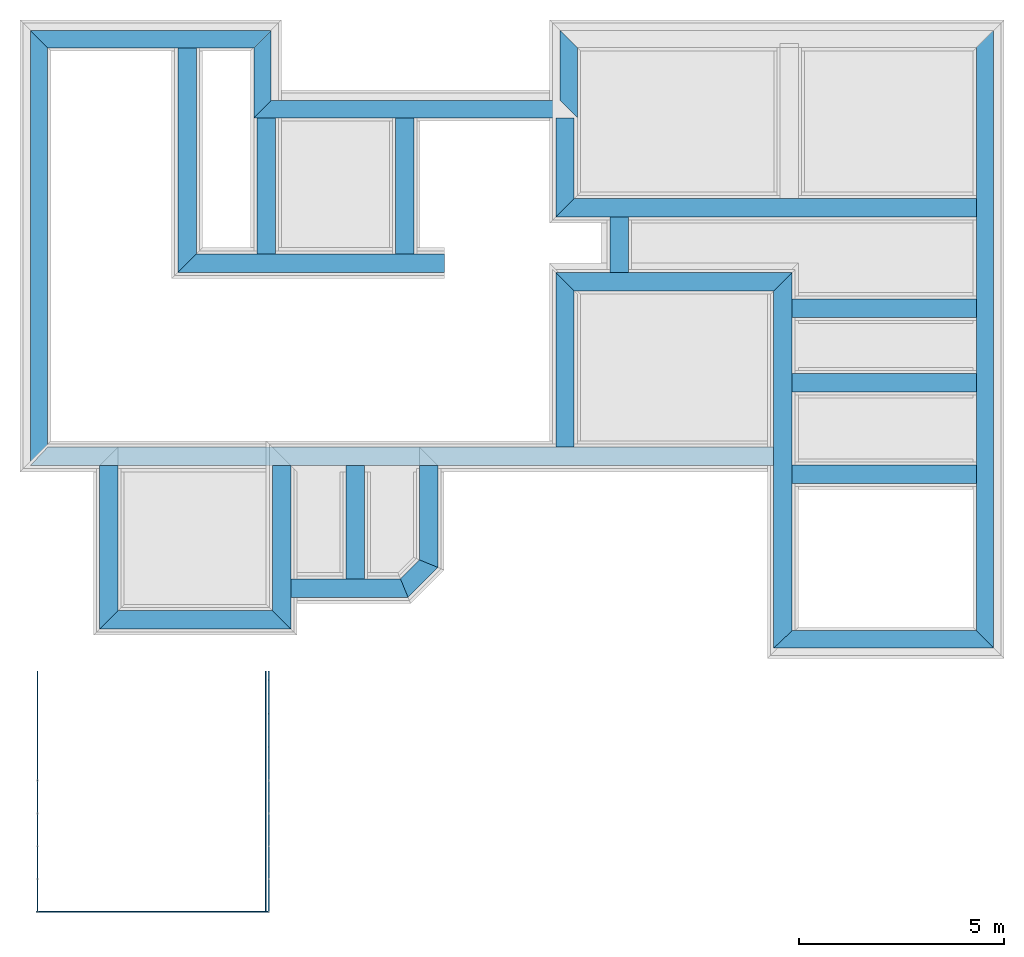
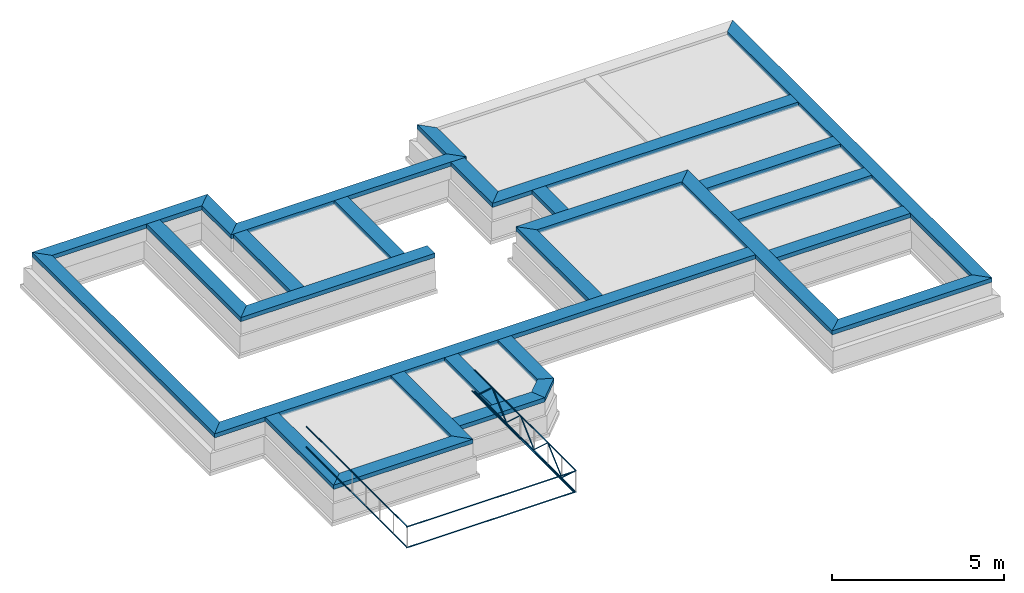
# One storey, part 1 of 7: 42 beams.
"""IFC4X3_ADD2 building model written with IfcOpenShell, lengths in metres."""

from ifc_helpers import new_model, entity, si_unit, converted_unit, frame, origin_with_axes, origin_2d_with_axis, place, context, subcontext, project, spatial, line, indexed_curve, hollow_rectangle, outline, extrude, material, layer, layer_set, layer_usage, material_profile, profile_set, profile_usage, type_object, element, save


model = new_model("IFC4X3_ADD2")

# Units and contexts
model_context = context("Model", 3, precision=1e-05, world=origin_with_axes())
plan_context = context("Plan", 2, precision=1e-05, world=origin_2d_with_axis())
body_context = subcontext(model_context, "Body", "Model", "MODEL_VIEW")
ifc_project = project(units=[si_unit("VOLUMEUNIT", "CUBIC_METRE"), si_unit("LENGTHUNIT", "METRE"), converted_unit("PLANEANGLEUNIT", "degree", entity("IfcReal", 0.0174532925199433), si_unit("PLANEANGLEUNIT", "RADIAN"), dimensions=[0, 0, 0, 0, 0, 0, 0]), si_unit("AREAUNIT", "SQUARE_METRE")], contexts=[model_context, plan_context])

# Site, building, storey
site_placement = place(None, origin_with_axes())
site = spatial("IfcSite", under=ifc_project, at=site_placement)
building_placement = place(site_placement, origin_with_axes())
building = spatial("IfcBuilding", under=site, at=building_placement, Name="Building")
storey_placement = place(building_placement, frame((0.0, 0.0, -0.870000004768372), z_axis=(0.0, 0.0, 1.0), x_axis=(1.0, 0.0, 0.0)))
storey = spatial("IfcBuildingStorey", under=building, at=storey_placement, Name="Footing")

# Beams
ifc_material_1 = material(Name="brick2", Category="Materials")
ifc_layer_1 = layer(ifc_material_1, 0.00999999977648258)
ifc_material_2 = material(Name="Concrete")
ifc_layer_2 = layer(ifc_material_2, 0.405000001192093)
ifc_layer_3 = layer(ifc_material_1, 0.00999999977648258)
ifc_layer_set_1 = layer_set([ifc_layer_1, ifc_layer_2, ifc_layer_3], Name="concrete")
ifc_layer_usage_1 = layer_usage(ifc_layer_set_1, "AXIS2", "POSITIVE", 0.0)
beam_type_1 = type_object("IfcBeamType", Name="425mm wide beam", PredefinedType="BEAM", material=ifc_layer_set_1)
beam_1_placement = place(storey_placement, frame((18.1166839599609, 25.9979019165039, 1.16999995708466), z_axis=(0.0, 0.0, 1.0), x_axis=(3.13916473260163e-07, -0.999999999999951, 0.0)))
element("IfcBeam", 1, at=beam_1_placement, inside=storey, type_object=beam_type_1, material=ifc_layer_usage_1, Name="Beam", context=body_context, shape_type="SweptSolid", body=[
    extrude(outline(indexed_curve([(-0.425000000745059, 0.0), (-1.85773430742357e-08, 0.425000000745058), (1.70799196416283, 0.425000000745058), (1.28299198199511, 0.0)], segments=[line(1, 2, 3, 4, 1)])), origin_with_axes(), (0.0, 0.0, 1.0), 0.150000005960464),
])
ifc_layer_usage_2 = layer_usage(ifc_layer_set_1, "AXIS2", "POSITIVE", 0.0)
beam_2_placement = place(storey_placement, frame((10.6593037587962, 24.2899072712673, 1.16999995708466), z_axis=(0.0, 0.0, 1.0), x_axis=(0.999999999999936, 3.57627868652321e-07, 0.0)))
element("IfcBeam", 2, at=beam_2_placement, inside=storey, type_object=beam_type_1, material=ifc_layer_usage_2, Name="Beam", context=body_context, shape_type="SweptSolid", body=[
    extrude(outline(indexed_curve([(0.0, 0.0), (0.425000048504974, 0.425000000745058), (7.45738073603171, 0.425000000745058), (7.88238071161483, 0.0)], segments=[line(1, 2, 3, 4, 1)])), origin_with_axes(), (0.0, 0.0, 1.0), 0.150000005960464),
])
ifc_layer_usage_3 = layer_usage(ifc_layer_set_1, "AXIS2", "POSITIVE", 0.0)
beam_3_placement = place(storey_placement, frame((28.2616729736329, 25.9979055491053, 1.16999995708466), z_axis=(0.0, 0.0, 1.0), x_axis=(3.13916473260163e-07, -0.999999999999951, 0.0)))
element("IfcBeam", 3, at=beam_3_placement, inside=storey, type_object=beam_type_1, material=ifc_layer_usage_3, Name="Beam", context=body_context, shape_type="SweptSolid", body=[
    extrude(outline(indexed_curve([(0.0, 0.0), (-0.425000019322402, 0.425000000745058), (14.6285606951178, 0.425000000745058), (14.2035607129501, 0.0)], segments=[line(1, 2, 3, 4, 1)])), origin_with_axes(), (0.0, 0.0, 1.0), 0.150000005960464),
])
ifc_layer_usage_4 = layer_usage(ifc_layer_set_1, "AXIS2", "POSITIVE", 0.0)
beam_4_placement = place(storey_placement, frame((23.3250172254903, 11.3693430699236, 1.16999995708466), z_axis=(0.0, 0.0, 1.0), x_axis=(0.999999999999936, 3.57627868652321e-07, 0.0)))
element("IfcBeam", 4, at=beam_4_placement, inside=storey, type_object=beam_type_1, material=ifc_layer_usage_4, Name="Beam", context=body_context, shape_type="SweptSolid", body=[
    extrude(outline(indexed_curve([(0.0, 0.0), (0.450000020620197, 0.425000000745058), (4.93666035886637, 0.425000000745058), (5.36166034103409, 0.0)], segments=[line(1, 2, 3, 4, 1)])), origin_with_axes(), (0.0, 0.0, 1.0), 0.150000005960464),
])
ifc_layer_usage_5 = layer_usage(ifc_layer_set_1, "AXIS2", "POSITIVE", 0.0)
beam_5_placement = place(storey_placement, frame((5.21403593350073, 25.9879012442737, 1.16999995708466), z_axis=(0.0, 0.0, 1.0), x_axis=(3.13916473260163e-07, -0.999999999999951, 0.0)))
element("IfcBeam", 5, at=beam_5_placement, inside=storey, type_object=beam_type_1, material=ifc_layer_usage_5, Name="Beam", context=body_context, shape_type="SweptSolid", body=[
    extrude(outline(indexed_curve([(-0.425000000745059, 0.0), (-1.85773430742357e-08, 0.425000000745058), (9.7218833779098, 0.425000000745058), (10.1718834035535, 0.0)], segments=[line(1, 2, 3, 4, 1)])), origin_with_axes(), (0.0, 0.0, 1.0), 0.150000005960464),
])
ifc_layer_usage_6 = layer_usage(ifc_layer_set_1, "AXIS2", "POSITIVE", 0.0)
beam_6_placement = place(storey_placement, frame((5.21403593350073, 25.9879012442737, 1.16999995708466), z_axis=(0.0, 0.0, 1.0), x_axis=(0.999999999999936, 3.57627868652321e-07, 0.0)))
element("IfcBeam", 6, at=beam_6_placement, inside=storey, type_object=beam_type_1, material=ifc_layer_usage_6, Name="Beam", context=body_context, shape_type="SweptSolid", body=[
    extrude(outline(indexed_curve([(0.425000000745059, 0.0), (1.96829825992962e-08, 0.425000000745058), (5.87026742918612, 0.425000000745058), (5.44526740885958, 0.0)], segments=[line(1, 2, 3, 4, 1)])), origin_with_axes(), (0.0, 0.0, 1.0), 0.150000005960464),
])
ifc_layer_usage_7 = layer_usage(ifc_layer_set_1, "AXIS2", "POSITIVE", 0.0)
beam_7_placement = place(storey_placement, frame((10.65930334236, 25.9879031916531, 1.16999995708466), z_axis=(0.0, 0.0, 1.0), x_axis=(3.13916473260163e-07, -0.999999999999951, 0.0)))
element("IfcBeam", 7, at=beam_7_placement, inside=storey, type_object=beam_type_1, material=ifc_layer_usage_7, Name="Beam", context=body_context, shape_type="SweptSolid", body=[
    extrude(outline(indexed_curve([(0.0, 0.0), (-0.425000019322402, 0.425000000745058), (1.2729959010635, 0.425000000745058), (1.6979959203859, 0.0)], segments=[line(1, 2, 3, 4, 1)])), origin_with_axes(), (0.0, 0.0, 1.0), 0.150000005960464),
])
ifc_layer_4 = layer(ifc_material_1, 0.00999999977648258)
ifc_material_3 = material(Name="Stone", Category="Structure")
ifc_layer_5 = layer(ifc_material_3, 0.430000007152557)
ifc_layer_6 = layer(ifc_material_1, 0.00999999977648258)
ifc_layer_set_2 = layer_set([ifc_layer_4, ifc_layer_5, ifc_layer_6], Name="concrete")
ifc_layer_usage_8 = layer_usage(ifc_layer_set_2, "AXIS2", "POSITIVE", 0.0)
beam_type_2 = type_object("IfcBeamType", Name="450mm wide beam", PredefinedType="BEAM", material=ifc_layer_set_2)
beam_8_placement = place(storey_placement, frame((8.80813704222451, 25.9978993535042, 1.16999995708466), z_axis=(0.0, 0.0, 1.0), x_axis=(1.94707183709394e-07, -0.999999999999981, 0.0)))
element("IfcBeam", 8, at=beam_8_placement, inside=storey, type_object=beam_type_2, material=ifc_layer_usage_8, Name="Beam", context=body_context, shape_type="SweptSolid", body=[
    extrude(outline(indexed_curve([(0.0, 0.0), (0.0, 0.450000006705522), (5.02351283316316, 0.450000006705522), (5.47351248493011, 0.0)], segments=[line(1, 2, 3, 4, 1)])), origin_with_axes(), (0.0, 0.0, 1.0), 0.150000005960464),
])
ifc_layer_usage_9 = layer_usage(ifc_layer_set_2, "AXIS2", "POSITIVE", 0.0)
beam_9_placement = place(storey_placement, frame((14.110216841721, 24.2899085054099, 1.16999995708466), z_axis=(0.0, 0.0, 1.0), x_axis=(3.13916473260163e-07, -0.999999999999951, 0.0)))
element("IfcBeam", 9, at=beam_9_placement, inside=storey, type_object=beam_type_2, material=ifc_layer_usage_9, Name="Beam", context=body_context, shape_type="SweptSolid", body=[
    extrude(outline(indexed_curve([(0.0, 0.0), (-1.96701282195799e-08, 0.450000006705522), (3.31552518321818, 0.450000006705522), (3.31552477503988, 0.0)], segments=[line(1, 2, 3, 4, 1)])), origin_with_axes(), (0.0, 0.0, 1.0), 0.150000005960464),
])
ifc_layer_usage_10 = layer_usage(ifc_layer_set_2, "AXIS2", "POSITIVE", 0.0)
beam_10_placement = place(storey_placement, frame((18.0166816711424, 24.2899099024706, 1.16999995708466), z_axis=(0.0, 0.0, 1.0), x_axis=(3.13916473260163e-07, -0.999999999999951, 0.0)))
element("IfcBeam", 10, at=beam_10_placement, inside=storey, type_object=beam_type_2, material=ifc_layer_usage_10, Name="Beam", context=body_context, shape_type="SweptSolid", body=[
    extrude(outline(indexed_curve([(0.0, 0.0), (-1.96701282195798e-08, 0.450000006705522), (1.96201718267913, 0.450000006705522), (2.41201721245263, 0.0)], segments=[line(1, 2, 3, 4, 1)])), origin_with_axes(), (0.0, 0.0, 1.0), 0.150000005960464),
])
ifc_layer_usage_11 = layer_usage(ifc_layer_set_2, "AXIS2", "POSITIVE", 0.0)
beam_11_placement = place(storey_placement, frame((18.0166824547765, 21.8778927056883, 1.16999995708466), z_axis=(0.0, 0.0, 1.0), x_axis=(0.999999999999936, 3.57627868652321e-07, 0.0)))
element("IfcBeam", 11, at=beam_11_placement, inside=storey, type_object=beam_type_2, material=ifc_layer_usage_11, Name="Beam", context=body_context, shape_type="SweptSolid", body=[
    extrude(outline(indexed_curve([(0.0, 0.0), (0.450000021438708, 0.450000006705522), (10.2449918318659, 0.450000006705522), (10.2449918121957, 0.0)], segments=[line(1, 2, 3, 4, 1)])), origin_with_axes(), (0.0, 0.0, 1.0), 0.150000005960464),
])
ifc_layer_usage_12 = layer_usage(ifc_layer_set_2, "AXIS2", "POSITIVE", 0.0)
beam_12_placement = place(storey_placement, frame((23.3250144526521, 20.0728968029, 1.16999995708466), z_axis=(0.0, 0.0, 1.0), x_axis=(3.13916473260163e-07, -0.999999999999951, 0.0)))
element("IfcBeam", 12, at=beam_12_placement, inside=storey, type_object=beam_type_2, material=ifc_layer_usage_12, Name="Beam", context=body_context, shape_type="SweptSolid", body=[
    extrude(outline(indexed_curve([(0.0, 0.0), (-0.450000027679134, 0.450000006705522), (8.2785537125617, 0.450000006705522), (8.70355373297689, 0.0)], segments=[line(1, 2, 3, 4, 1)])), origin_with_axes(), (0.0, 0.0, 1.0), 0.150000005960464),
])
ifc_layer_usage_13 = layer_usage(ifc_layer_set_2, "AXIS2", "POSITIVE", 0.0)
beam_13_placement = place(storey_placement, frame((18.0166815696099, 20.072894889116, 1.16999995708466), z_axis=(0.0, 0.0, 1.0), x_axis=(0.999999999999936, 3.57627868652321e-07, 0.0)))
element("IfcBeam", 13, at=beam_13_placement, inside=storey, type_object=beam_type_2, material=ifc_layer_usage_13, Name="Beam", context=body_context, shape_type="SweptSolid", body=[
    extrude(outline(indexed_curve([(0.450000006705523, 0.0), (1.96701282484391e-08, 0.450000006705522), (5.75833290805005, 0.450000006705522), (5.30833288304257, 0.0)], segments=[line(1, 2, 3, 4, 1)])), origin_with_axes(), (0.0, 0.0, 1.0), 0.150000005960464),
])
ifc_layer_usage_14 = layer_usage(ifc_layer_set_2, "AXIS2", "POSITIVE", 0.0)
beam_14_placement = place(storey_placement, frame((23.3250146565525, 19.4295903581414, 1.16999995708466), z_axis=(0.0, 0.0, 1.0), x_axis=(0.999999999999936, 3.57627868652321e-07, 0.0)))
element("IfcBeam", 14, at=beam_14_placement, inside=storey, type_object=beam_type_2, material=ifc_layer_usage_14, Name="Beam", context=body_context, shape_type="SweptSolid", body=[
    extrude(outline(indexed_curve([(0.450000006705522, 0.0), (0.450000025007475, 0.450000006705522), (4.93666039865257, 0.450000006705522), (4.93666037898244, 0.0)], segments=[line(1, 2, 3, 4, 1)])), origin_with_axes(), (0.0, 0.0, 1.0), 0.150000005960464),
])
ifc_layer_usage_15 = layer_usage(ifc_layer_set_2, "AXIS2", "POSITIVE", 0.0)
beam_15_placement = place(storey_placement, frame((23.3250141143799, 17.6093635559082, 1.16999995708466), z_axis=(0.0, 0.0, 1.0), x_axis=(0.999999999999936, 3.57627868652321e-07, 0.0)))
element("IfcBeam", 15, at=beam_15_placement, inside=storey, type_object=beam_type_2, material=ifc_layer_usage_15, Name="Beam", context=body_context, shape_type="SweptSolid", body=[
    extrude(outline(indexed_curve([(0.450000006705522, 0.0), (0.450000025007475, 0.450000006705522), (4.93666039865257, 0.450000006705522), (4.93666037898244, 0.0)], segments=[line(1, 2, 3, 4, 1)])), origin_with_axes(), (0.0, 0.0, 1.0), 0.150000005960464),
])
ifc_layer_usage_16 = layer_usage(ifc_layer_set_2, "AXIS2", "POSITIVE", 0.0)
beam_16_placement = place(storey_placement, frame((23.3250141143799, 15.3793487548828, 1.16999995708466), z_axis=(0.0, 0.0, 1.0), x_axis=(0.999999999999936, 3.57627868652321e-07, 0.0)))
element("IfcBeam", 16, at=beam_16_placement, inside=storey, type_object=beam_type_2, material=ifc_layer_usage_16, Name="Beam", context=body_context, shape_type="SweptSolid", body=[
    extrude(outline(indexed_curve([(0.450000006705522, 0.0), (0.450000025007475, 0.450000006705522), (4.93666039865257, 0.450000006705522), (4.93666037898244, 0.0)], segments=[line(1, 2, 3, 4, 1)])), origin_with_axes(), (0.0, 0.0, 1.0), 0.150000005960464),
])
ifc_layer_usage_17 = layer_usage(ifc_layer_set_2, "AXIS2", "POSITIVE", 0.0)
beam_17_placement = place(storey_placement, frame((19.3416843414307, 21.877893447876, 1.16999995708466), z_axis=(0.0, 0.0, 1.0), x_axis=(3.13916473260163e-07, -0.999999999999951, 0.0)))
element("IfcBeam", 17, at=beam_17_placement, inside=storey, type_object=beam_type_2, material=ifc_layer_usage_17, Name="Beam", context=body_context, shape_type="SweptSolid", body=[
    extrude(outline(indexed_curve([(0.0, 0.0), (-2.08324514101375e-08, 0.450000006705522), (1.35499778938149, 0.450000006705522), (1.35499781047584, 0.0)], segments=[line(1, 2, 3, 4, 1)])), origin_with_axes(), (0.0, 0.0, 1.0), 0.150000005960464),
])
ifc_layer_usage_18 = layer_usage(ifc_layer_set_2, "AXIS2", "POSITIVE", 0.0)
beam_18_placement = place(storey_placement, frame((18.0166815696099, 20.0728948876918, 1.16999995708466), z_axis=(0.0, 0.0, 1.0), x_axis=(3.13916473260163e-07, -0.999999999999951, 0.0)))
element("IfcBeam", 18, at=beam_18_placement, inside=storey, type_object=beam_type_2, material=ifc_layer_usage_18, Name="Beam", context=body_context, shape_type="SweptSolid", body=[
    extrude(outline(indexed_curve([(-0.450000006705523, 0.0), (-2.09736109838054e-08, 0.450000006705522), (3.80687243920009, 0.450000006705522), (3.80687245990194, 0.0)], segments=[line(1, 2, 3, 4, 1)])), origin_with_axes(), (0.0, 0.0, 1.0), 0.150000005960464),
])
ifc_layer_usage_19 = layer_usage(ifc_layer_set_2, "AXIS2", "POSITIVE", 0.0)
beam_19_placement = place(storey_placement, frame((5.21403910016029, 15.8160178407207, 1.16999995708466), z_axis=(0.0, 0.0, 1.0), x_axis=(0.999999999999936, 3.57627868652321e-07, 0.0)))
element("IfcBeam", 19, at=beam_19_placement, inside=storey, type_object=beam_type_2, material=ifc_layer_usage_19, Name="Beam", context=body_context, shape_type="SweptSolid", body=[
    extrude(outline(indexed_curve([(0.0, 0.0), (0.425000021585864, 0.450000006705522), (18.1109767200399, 0.450000006705522), (18.1109767017379, 0.0)], segments=[line(1, 2, 3, 4, 1)])), origin_with_axes(), (0.0, 0.0, 1.0), 0.150000005960464),
])
ifc_layer_usage_20 = layer_usage(ifc_layer_set_2, "AXIS2", "POSITIVE", 0.0)
beam_20_placement = place(storey_placement, frame((14.6966757752904, 15.8160212390453, 1.16999995708466), z_axis=(0.0, 0.0, 1.0), x_axis=(3.13916473260163e-07, -0.999999999999951, 0.0)))
element("IfcBeam", 20, at=beam_20_placement, inside=storey, type_object=beam_type_2, material=ifc_layer_usage_20, Name="Beam", context=body_context, shape_type="SweptSolid", body=[
    extrude(outline(indexed_curve([(0.0, 0.0), (-2.0103359660383e-08, 0.450000006705522), (2.48110810332906, 0.450000006705522), (2.29471198139448, 0.0)], segments=[line(1, 2, 3, 4, 1)])), origin_with_axes(), (0.0, 0.0, 1.0), 0.150000005960464),
])
ifc_layer_usage_21 = layer_usage(ifc_layer_set_2, "AXIS2", "POSITIVE", 0.0)
beam_21_placement = place(storey_placement, frame((14.6966764956383, 13.5213092576509, 1.16999995708466), z_axis=(0.0, 0.0, 1.0), x_axis=(-0.707106602372588, -0.707106960000462, 0.0)))
element("IfcBeam", 21, at=beam_21_placement, inside=storey, type_object=beam_type_2, material=ifc_layer_usage_21, Name="Beam", context=body_context, shape_type="SweptSolid", body=[
    extrude(outline(indexed_curve([(0.0, 0.0), (-0.186396121934575, 0.450000006705522), (0.842713639025092, 0.450000006705522), (0.65631756226547, 0.0)], segments=[line(1, 2, 3, 4, 1)])), origin_with_axes(), (0.0, 0.0, 1.0), 0.150000005960464),
])
ifc_layer_usage_22 = layer_usage(ifc_layer_set_2, "AXIS2", "POSITIVE", 0.0)
beam_22_placement = place(storey_placement, frame((11.1129999696974, 12.6072214047061, 1.16999995708466), z_axis=(0.0, 0.0, 1.0), x_axis=(0.999999999999936, 3.57627868652321e-07, 0.0)))
element("IfcBeam", 22, at=beam_22_placement, inside=storey, type_object=beam_type_2, material=ifc_layer_usage_22, Name="Beam", context=body_context, shape_type="SweptSolid", body=[
    extrude(outline(indexed_curve([(0.450000006705523, 0.0), (0.450000026375651, 0.450000006705522), (3.11959019100417, 0.450000006705522), (3.30598626923792, 0.0)], segments=[line(1, 2, 3, 4, 1)])), origin_with_axes(), (0.0, 0.0, 1.0), 0.150000005960464),
])
ifc_layer_usage_23 = layer_usage(ifc_layer_set_2, "AXIS2", "POSITIVE", 0.0)
beam_23_placement = place(storey_placement, frame((12.9089555740357, 15.8160205991703, 1.16999995708466), z_axis=(0.0, 0.0, 1.0), x_axis=(3.13916473260163e-07, -0.999999999999951, 0.0)))
element("IfcBeam", 23, at=beam_23_placement, inside=storey, type_object=beam_type_2, material=ifc_layer_usage_23, Name="Beam", context=body_context, shape_type="SweptSolid", body=[
    extrude(outline(indexed_curve([(0.0, 0.0), (-2.00521794216641e-08, 0.450000006705522), (2.75879851585852, 0.450000006705522), (2.75879853752143, 0.0)], segments=[line(1, 2, 3, 4, 1)])), origin_with_axes(), (0.0, 0.0, 1.0), 0.150000005960464),
])
ifc_layer_usage_24 = layer_usage(ifc_layer_set_2, "AXIS2", "POSITIVE", 0.0)
beam_24_placement = place(storey_placement, frame((11.1129989624023, 15.8160209655762, 1.16999995708466), z_axis=(0.0, 0.0, 1.0), x_axis=(3.13916473260163e-07, -0.999999999999951, 0.0)))
element("IfcBeam", 24, at=beam_24_placement, inside=storey, type_object=beam_type_2, material=ifc_layer_usage_24, Name="Beam", context=body_context, shape_type="SweptSolid", body=[
    extrude(outline(indexed_curve([(0.0, 0.0), (0.0, 0.450000006705522), (3.9799980040806, 0.450000006705522), (3.52999801830902, 0.0)], segments=[line(1, 2, 3, 4, 1)])), origin_with_axes(), (0.0, 0.0, 1.0), 0.150000005960464),
])
ifc_layer_usage_25 = layer_usage(ifc_layer_set_2, "AXIS2", "POSITIVE", 0.0)
beam_25_placement = place(storey_placement, frame((6.9035966969277, 11.8360214233398, 1.16999995708466), z_axis=(0.0, 0.0, 1.0), x_axis=(0.999999999999936, 3.57627868652321e-07, 0.0)))
element("IfcBeam", 25, at=beam_25_placement, inside=storey, type_object=beam_type_2, material=ifc_layer_usage_25, Name="Beam", context=body_context, shape_type="SweptSolid", body=[
    extrude(outline(indexed_curve([(0.0, 0.0), (0.450000026375651, 0.450000006705522), (4.20940353453194, 0.450000006705522), (4.65940352156734, 0.0)], segments=[line(1, 2, 3, 4, 1)])), origin_with_axes(), (0.0, 0.0, 1.0), 0.150000005960464),
])
ifc_layer_usage_26 = layer_usage(ifc_layer_set_2, "AXIS2", "POSITIVE", 0.0)
beam_26_placement = place(storey_placement, frame((6.90359544754028, 15.8160209655762, 1.16999995708466), z_axis=(0.0, 0.0, 1.0), x_axis=(3.13916473260163e-07, -0.999999999999951, 0.0)))
element("IfcBeam", 26, at=beam_26_placement, inside=storey, type_object=beam_type_2, material=ifc_layer_usage_26, Name="Beam", context=body_context, shape_type="SweptSolid", body=[
    extrude(outline(indexed_curve([(0.0, 0.0), (0.0, 0.450000006705522), (3.52999951459715, 0.450000006705522), (3.97999954223662, 0.0)], segments=[line(1, 2, 3, 4, 1)])), origin_with_axes(), (0.0, 0.0, 1.0), 0.150000005960464),
])
ifc_layer_usage_27 = layer_usage(ifc_layer_set_2, "AXIS2", "POSITIVE", 0.0)
beam_27_placement = place(storey_placement, frame((10.734302408552, 24.2899072980889, 1.16999995708466), z_axis=(0.0, 0.0, 1.0), x_axis=(3.13916473260163e-07, -0.999999999999951, 0.0)))
element("IfcBeam", 27, at=beam_27_placement, inside=storey, type_object=beam_type_2, material=ifc_layer_usage_27, Name="Beam", context=body_context, shape_type="SweptSolid", body=[
    extrude(outline(indexed_curve([(0.0, 0.0), (-1.96701281929279e-08, 0.450000006705522), (3.31552197348559, 0.450000006705522), (3.31552156530729, 0.0)], segments=[line(1, 2, 3, 4, 1)])), origin_with_axes(), (0.0, 0.0, 1.0), 0.150000005960464),
])
ifc_layer_usage_28 = layer_usage(ifc_layer_set_2, "AXIS2", "POSITIVE", 0.0)
beam_28_placement = place(storey_placement, frame((8.80813810795671, 20.5243868685742, 1.16999995708466), z_axis=(0.0, 0.0, 1.0), x_axis=(0.999999999999822, -5.960464477538e-07, 0.0)))
element("IfcBeam", 28, at=beam_28_placement, inside=storey, type_object=beam_type_2, material=ifc_layer_usage_28, Name="Beam", context=body_context, shape_type="SweptSolid", body=[
    extrude(outline(indexed_curve([(0.0, 0.0), (0.449999650866523, 0.450000006705522), (6.50208187103272, 0.450000006705522), (6.50208187103272, 0.0)], segments=[line(1, 2, 3, 4, 1)])), origin_with_axes(), (0.0, 0.0, 1.0), 0.150000005960464),
])
ifc_material_4 = material(Name="Brick")
ifc_material_profile = material_profile(ifc_material_4, hollow_rectangle(XDim=0.0320000015199184, YDim=0.0320000015199184, WallThickness=0.0020000000949949, InnerFilletRadius=0.0020000000949949, OuterFilletRadius=0.00400000018998981))
ifc_profile_set = profile_set([ifc_material_profile])
ifc_profile_usage_1 = profile_usage(ifc_profile_set, cardinal=5)
beam_type_3 = type_object("IfcBeamType", Name="SHS_0.032x0.032x0", PredefinedType="BEAM", material=ifc_profile_set)
beam_29_placement = place(storey_placement, frame((5.39050388336182, 4.94458627700806, 4.5585333108902), z_axis=(1.5099578831723e-07, 0.999999999999986, 7.54979012640422e-08), x_axis=(-0.999999999999984, 1.50995802528084e-07, -9.83464900627935e-08)))
element("IfcBeam", 29, at=beam_29_placement, inside=storey, type_object=beam_type_3, material=ifc_profile_usage_1, Name="Beam", context=body_context, shape_type="SweptSolid", body=[
    extrude(hollow_rectangle(XDim=0.0320000015199184, YDim=0.0320000015199184, WallThickness=0.0020000000949949, InnerFilletRadius=0.0020000000949949, OuterFilletRadius=0.00400000018998981), origin_with_axes(), (0.0, 0.0, 1.0), 5.86349822372949),
])
ifc_profile_usage_2 = profile_usage(ifc_profile_set, cardinal=5)
beam_30_placement = place(storey_placement, frame((5.39050388336182, 4.94458627700806, 3.82610189914703), z_axis=(1.5099578831723e-07, 0.999999999999986, 7.54979012640422e-08), x_axis=(-0.999999999999984, 1.50995802528084e-07, -9.83464829573661e-08)))
element("IfcBeam", 30, at=beam_30_placement, inside=storey, type_object=beam_type_3, material=ifc_profile_usage_2, Name="Beam", context=body_context, shape_type="SweptSolid", body=[
    extrude(hollow_rectangle(XDim=0.0320000015199184, YDim=0.0320000015199184, WallThickness=0.0020000000949949, InnerFilletRadius=0.0020000000949949, OuterFilletRadius=0.00400000018998981), origin_with_axes(), (0.0, 0.0, 1.0), 5.86349822372949),
])
ifc_profile_usage_3 = profile_usage(ifc_profile_set, cardinal=5)
beam_31_placement = place(storey_placement, frame((10.9474782943726, 4.94458627700806, 3.86446702480316), z_axis=(1.5099578831723e-07, 0.999999999999986, 7.54979012640422e-08), x_axis=(-0.999999999999984, 1.50995802528084e-07, -9.83464829573661e-08)))
element("IfcBeam", 31, at=beam_31_placement, inside=storey, type_object=beam_type_3, material=ifc_profile_usage_3, Name="Beam", context=body_context, shape_type="SweptSolid", body=[
    extrude(hollow_rectangle(XDim=0.0320000015199184, YDim=0.0320000015199184, WallThickness=0.0020000000949949, InnerFilletRadius=0.0020000000949949, OuterFilletRadius=0.00400000018998981), origin_with_axes(), (0.0, 0.0, 1.0), 5.86349822372949),
])
ifc_profile_usage_4 = profile_usage(ifc_profile_set, cardinal=5)
beam_32_placement = place(storey_placement, frame((11.0242557525635, 4.92858505249023, 3.82610189914703), z_axis=(1.5099578831723e-07, 0.999999999999986, 7.54979012640422e-08), x_axis=(-0.999999999999984, 1.50995802528084e-07, -9.83464829573661e-08)))
element("IfcBeam", 32, at=beam_32_placement, inside=storey, type_object=beam_type_3, material=ifc_profile_usage_4, Name="Beam", context=body_context, shape_type="SweptSolid", body=[
    extrude(hollow_rectangle(XDim=0.0320000015199184, YDim=0.0320000015199184, WallThickness=0.0020000000949949, InnerFilletRadius=0.0020000000949949, OuterFilletRadius=0.00400000018998981), origin_with_axes(), (0.0, 0.0, 1.0), 5.87949929525396),
])
ifc_profile_usage_5 = profile_usage(ifc_profile_set, cardinal=5)
beam_33_placement = place(storey_placement, frame((11.0242557525635, 4.92858505249023, 4.58610188961029), z_axis=(1.5099578831723e-07, 0.999999999999986, 7.54979012640422e-08), x_axis=(-0.999999999999984, 1.50995802528084e-07, -9.83464829573661e-08)))
element("IfcBeam", 33, at=beam_33_placement, inside=storey, type_object=beam_type_3, material=ifc_profile_usage_5, Name="Beam", context=body_context, shape_type="SweptSolid", body=[
    extrude(hollow_rectangle(XDim=0.0320000015199184, YDim=0.0320000015199184, WallThickness=0.0020000000949949, InnerFilletRadius=0.0020000000949949, OuterFilletRadius=0.00400000018998981), origin_with_axes(), (0.0, 0.0, 1.0), 5.87949929525396),
])
ifc_profile_usage_6 = profile_usage(ifc_profile_set, cardinal=5)
beam_34_placement = place(storey_placement, frame((5.35729646682739, 4.94458627700806, 4.55853283405304), z_axis=(0.999999999999978, -1.94707183709393e-07, 7.54979012640417e-08), x_axis=(1.94707183709392e-07, 0.999999999999974, -1.19209275339923e-07)))
element("IfcBeam", 34, at=beam_34_placement, inside=storey, type_object=beam_type_3, material=ifc_profile_usage_6, Name="Beam", context=body_context, shape_type="SweptSolid", body=[
    extrude(hollow_rectangle(XDim=0.0320000015199184, YDim=0.0320000015199184, WallThickness=0.0020000000949949, InnerFilletRadius=0.0020000000949949, OuterFilletRadius=0.00400000018998981), origin_with_axes(), (0.0, 0.0, 1.0), 5.65095955456507),
])
ifc_profile_usage_7 = profile_usage(ifc_profile_set, cardinal=5)
beam_35_placement = place(storey_placement, frame((5.35729646682739, 4.94458627700806, 3.82610189914703), z_axis=(0.999999999999978, -1.94707183709393e-07, 7.54979012640417e-08), x_axis=(1.94707183709393e-07, 0.999999999999976, -9.8346475851938e-08)))
element("IfcBeam", 35, at=beam_35_placement, inside=storey, type_object=beam_type_3, material=ifc_profile_usage_7, Name="Beam", context=body_context, shape_type="SweptSolid", body=[
    extrude(hollow_rectangle(XDim=0.0320000015199184, YDim=0.0320000015199184, WallThickness=0.0020000000949949, InnerFilletRadius=0.0020000000949949, OuterFilletRadius=0.00400000018998981), origin_with_axes(), (0.0, 0.0, 1.0), 5.65095955456507),
])
ifc_profile_usage_8 = profile_usage(ifc_profile_set, cardinal=5)
beam_36_placement = place(storey_placement, frame((11.0242557525635, 4.92858505249023, 4.58610188961029), z_axis=(2.29074875275903e-07, 0.739098622057347, -0.673597228967636), x_axis=(-0.999999999999973, 1.50995802528083e-07, -1.74398110175384e-07)))
element("IfcBeam", 36, at=beam_36_placement, inside=storey, type_object=beam_type_3, material=ifc_profile_usage_8, Name="Beam", context=body_context, shape_type="SweptSolid", body=[
    extrude(hollow_rectangle(XDim=0.0320000015199184, YDim=0.0320000015199184, WallThickness=0.0020000000949949, InnerFilletRadius=0.0020000000949949, OuterFilletRadius=0.00400000018998981), origin_with_axes(), (0.0, 0.0, 1.0), 1.092729010203),
])
ifc_profile_usage_9 = profile_usage(ifc_profile_set, cardinal=5)
beam_37_placement = place(storey_placement, frame((11.0242557525635, 6.55252647399902, 4.58610188961029), z_axis=(2.29074875275903e-07, 0.739098622057347, -0.673597228967636), x_axis=(-0.999999999999973, 1.50995802528083e-07, -1.74398110175384e-07)))
element("IfcBeam", 37, at=beam_37_placement, inside=storey, type_object=beam_type_3, material=ifc_profile_usage_9, Name="Beam", context=body_context, shape_type="SweptSolid", body=[
    extrude(hollow_rectangle(XDim=0.0320000015199184, YDim=0.0320000015199184, WallThickness=0.0020000000949949, InnerFilletRadius=0.0020000000949949, OuterFilletRadius=0.00400000018998981), origin_with_axes(), (0.0, 0.0, 1.0), 1.092729010203),
])
ifc_profile_usage_10 = profile_usage(ifc_profile_set, cardinal=5)
beam_38_placement = place(storey_placement, frame((11.0242557525635, 6.55252647399902, 4.58610188961029), z_axis=(1.17540326297504e-08, -0.739098622057367, -0.673597228967654), x_axis=(0.99999999999997, 1.74845553146946e-07, -1.74398110175384e-07)))
element("IfcBeam", 38, at=beam_38_placement, inside=storey, type_object=beam_type_3, material=ifc_profile_usage_10, Name="Beam", context=body_context, shape_type="SweptSolid", body=[
    extrude(hollow_rectangle(XDim=0.0320000015199184, YDim=0.0320000015199184, WallThickness=0.0020000000949949, InnerFilletRadius=0.0020000000949949, OuterFilletRadius=0.00400000018998981), origin_with_axes(), (0.0, 0.0, 1.0), 1.092729010203),
])
ifc_profile_usage_11 = profile_usage(ifc_profile_set, cardinal=5)
beam_39_placement = place(storey_placement, frame((11.0242557525635, 8.14837074279785, 4.58610188961029), z_axis=(2.29074875275903e-07, 0.739098622057347, -0.673597228967636), x_axis=(-0.999999999999973, 1.50995802528083e-07, -1.74398110175384e-07)))
element("IfcBeam", 39, at=beam_39_placement, inside=storey, type_object=beam_type_3, material=ifc_profile_usage_11, Name="Beam", context=body_context, shape_type="SweptSolid", body=[
    extrude(hollow_rectangle(XDim=0.0320000015199184, YDim=0.0320000015199184, WallThickness=0.0020000000949949, InnerFilletRadius=0.0020000000949949, OuterFilletRadius=0.00400000018998981), origin_with_axes(), (0.0, 0.0, 1.0), 1.092729010203),
])
ifc_profile_usage_12 = profile_usage(ifc_profile_set, cardinal=5)
beam_40_placement = place(storey_placement, frame((11.0242557525635, 9.77231216430664, 4.58610188961029), z_axis=(2.29074875275903e-07, 0.739098622057347, -0.673597228967636), x_axis=(-0.999999999999973, 1.50995802528083e-07, -1.74398110175384e-07)))
element("IfcBeam", 40, at=beam_40_placement, inside=storey, type_object=beam_type_3, material=ifc_profile_usage_12, Name="Beam", context=body_context, shape_type="SweptSolid", body=[
    extrude(hollow_rectangle(XDim=0.0320000015199184, YDim=0.0320000015199184, WallThickness=0.0020000000949949, InnerFilletRadius=0.0020000000949949, OuterFilletRadius=0.00400000018998981), origin_with_axes(), (0.0, 0.0, 1.0), 1.092729010203),
])
ifc_profile_usage_13 = profile_usage(ifc_profile_set, cardinal=5)
beam_41_placement = place(storey_placement, frame((11.0242557525635, 9.77231216430664, 4.58610188961029), z_axis=(1.17540326297504e-08, -0.739098622057367, -0.673597228967654), x_axis=(0.99999999999997, 1.74845553146946e-07, -1.74398110175384e-07)))
element("IfcBeam", 41, at=beam_41_placement, inside=storey, type_object=beam_type_3, material=ifc_profile_usage_13, Name="Beam", context=body_context, shape_type="SweptSolid", body=[
    extrude(hollow_rectangle(XDim=0.0320000015199184, YDim=0.0320000015199184, WallThickness=0.0020000000949949, InnerFilletRadius=0.0020000000949949, OuterFilletRadius=0.00400000018998981), origin_with_axes(), (0.0, 0.0, 1.0), 1.092729010203),
])
ifc_profile_usage_14 = profile_usage(ifc_profile_set, cardinal=5)
beam_42_placement = place(storey_placement, frame((11.0242557525635, 8.14404392242432, 4.58610188961029), z_axis=(1.17540326297504e-08, -0.739098622057367, -0.673597228967654), x_axis=(0.99999999999997, 1.74845553146946e-07, -1.74398110175384e-07)))
element("IfcBeam", 42, at=beam_42_placement, inside=storey, type_object=beam_type_3, material=ifc_profile_usage_14, Name="Beam", context=body_context, shape_type="SweptSolid", body=[
    extrude(hollow_rectangle(XDim=0.0320000015199184, YDim=0.0320000015199184, WallThickness=0.0020000000949949, InnerFilletRadius=0.0020000000949949, OuterFilletRadius=0.00400000018998981), origin_with_axes(), (0.0, 0.0, 1.0), 1.092729010203),
])

save(model, "model.ifc")
